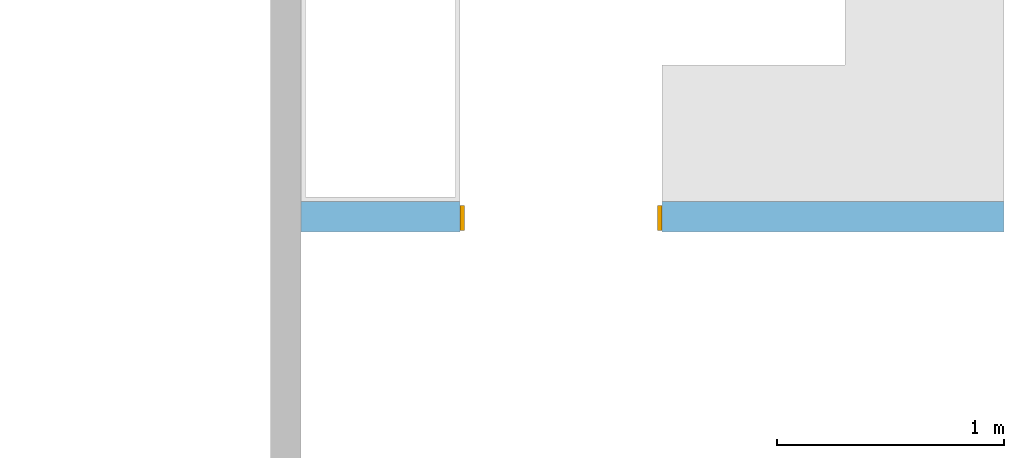
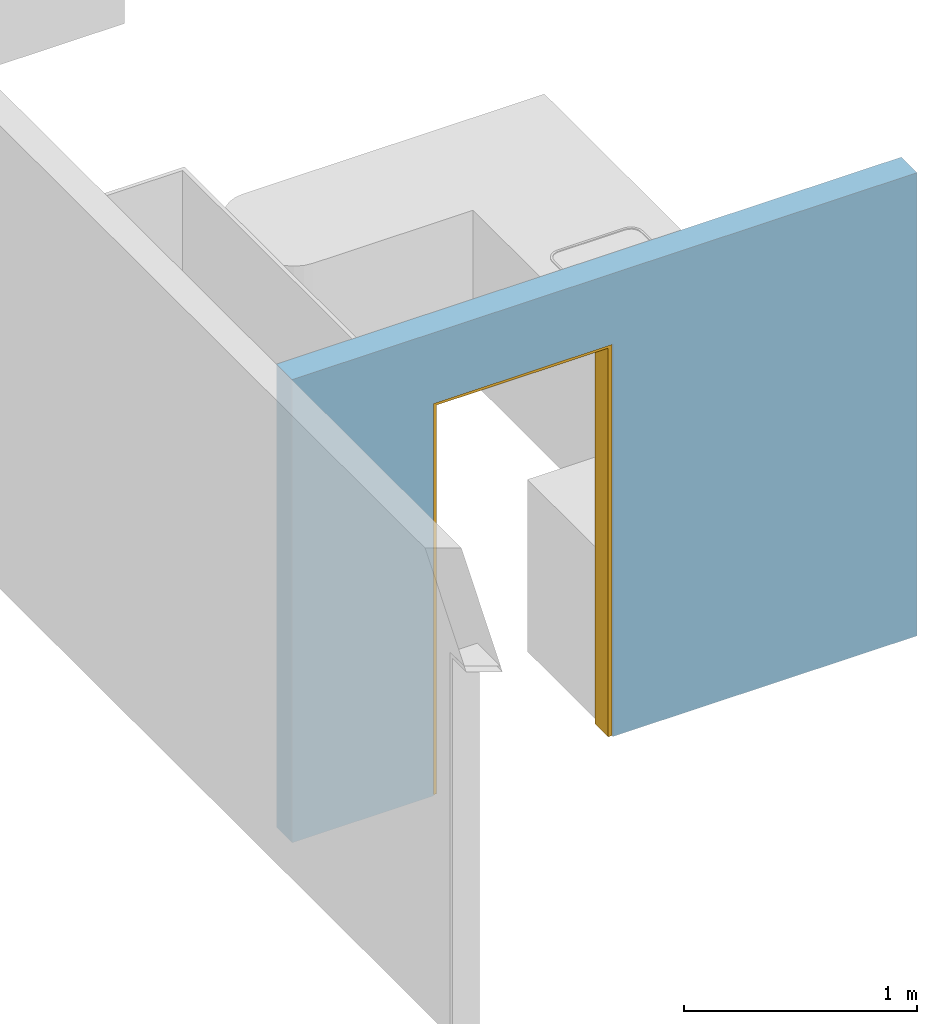
# One storey, part 3 of 6: 1 door, 1 opening, plus 1 element that does not belong to this part.
"""IFC4 building model written with IfcOpenShell, lengths in millimetres."""

import ifcopenshell
import ifcopenshell.guid

model = None  # the IFC model being written
_history = None  # IfcOwnerHistory: only IFC2X3 demands one
_inside = {}  # id of a spatial element -> (the spatial element, [elements in it])
_under = {}  # id of a project, library or spatial element -> (it, [spatial elements below it])
_declared = {}  # id of a project -> (the project, [libraries it declares])
_typed = {}  # id of a type object -> (the type object, [elements of that type])
_made_of = {}  # id of a material, layer set ... -> (it, [elements and type objects made of it])


def new_model(schema):
    """Start an empty IFC model of exactly this schema.

    Asked for "IFC4X3", IfcOpenShell would pick the latest addendum, in which some entities
    have other attributes; the version numbers below select the first issue.
    IFC2X3 requires an IfcOwnerHistory on every rooted entity: one is made here for all.
    """
    global model, _history
    if schema == "IFC4X3":
        model = ifcopenshell.file(schema_version=(4, 3, 0, 0))
    else:
        model = ifcopenshell.file(schema=schema)
    _inside.clear()
    _under.clear()
    _declared.clear()
    _typed.clear()
    _made_of.clear()
    _history = None
    if model.schema == "IFC2X3":
        org = make("IfcOrganization", Name="unknown")
        user = make(
            "IfcPersonAndOrganization",
            ThePerson=make("IfcPerson", FamilyName="unknown"),
            TheOrganization=org,
        )
        app = make(
            "IfcApplication",
            ApplicationDeveloper=org,
            Version="unknown",
            ApplicationFullName="unknown",
            ApplicationIdentifier="unknown",
        )
        _history = make(
            "IfcOwnerHistory",
            OwningUser=user,
            OwningApplication=app,
            ChangeAction="ADDED",
            CreationDate=0,
        )
    return model


def make(cls, **values):
    """One entity of the class cls with the attributes given. An attribute that is None is left unset."""
    return model.create_entity(
        cls, **{name: value for name, value in values.items() if value is not None}
    )


def entity(cls, *values):
    """Any entity or typed value of the class cls, its attributes in the order of the schema. None: left unset."""
    e = model.create_entity(cls)
    for i, value in enumerate(values):
        if value is not None:
            e[i] = value
    return e


def rooted(cls, **values):
    """An entity with a GlobalId (a new one), such as an element, a storey or a relation."""
    return make(cls, GlobalId=ifcopenshell.guid.new(), OwnerHistory=_history, **values)


def si_unit(unit_type, name, prefix=None):
    """IfcSIUnit, for example si_unit("LENGTHUNIT", "METRE", prefix="MILLI")."""
    return make("IfcSIUnit", UnitType=unit_type, Prefix=prefix, Name=name)


def converted_unit(unit_type, name, factor, base, dimensions=None, offset=None):
    """IfcConversionBasedUnit, such as the inch: factor (a typed value) times the base unit."""
    return make(
        "IfcConversionBasedUnit"
        if offset is None
        else "IfcConversionBasedUnitWithOffset",
        ConversionOffset=offset,
        Dimensions=None
        if dimensions is None
        else entity("IfcDimensionalExponents", *dimensions),
        UnitType=unit_type,
        Name=name,
        ConversionFactor=make(
            "IfcMeasureWithUnit", ValueComponent=factor, UnitComponent=base
        ),
    )


def assignment(units):
    """IfcUnitAssignment: the units of a project."""
    return None if units is None else make("IfcUnitAssignment", Units=units)


def point(xyz):
    """IfcCartesianPoint."""
    return None if xyz is None else make("IfcCartesianPoint", Coordinates=xyz)


def direction(xyz):
    """IfcDirection."""
    return None if xyz is None else make("IfcDirection", DirectionRatios=xyz)


def frame(location, z_axis=None, x_axis=None):
    """IfcAxis2Placement3D, a coordinate frame: its origin and axes. An axis left out is left unset."""
    return make(
        "IfcAxis2Placement3D",
        Location=point(location),
        Axis=direction(z_axis),
        RefDirection=direction(x_axis),
    )


def frame_2d(location, x_axis=None):
    """IfcAxis2Placement2D, a coordinate frame in the plane: its origin and x axis."""
    return make(
        "IfcAxis2Placement2D", Location=point(location), RefDirection=direction(x_axis)
    )


def origin_with_axes():
    """The frame at (0, 0, 0) with the z axis (0, 0, 1) and the x axis (1, 0, 0) written out."""
    return frame((0.0, 0.0, 0.0), z_axis=(0.0, 0.0, 1.0), x_axis=(1.0, 0.0, 0.0))


def origin_2d_with_axis():
    """The frame at (0, 0) in the plane with the x axis (1, 0) written out."""
    return frame_2d((0.0, 0.0), x_axis=(1.0, 0.0))


def place(relative_to, where):
    """IfcLocalPlacement: puts the frame where relative to a parent placement (None: the world)."""
    return make(
        "IfcLocalPlacement", PlacementRelTo=relative_to, RelativePlacement=where
    )


def context(
    kind, dimensions, precision=None, world=None, true_north=None, identifier=None
):
    """IfcGeometricRepresentationContext, for example the 3D "Model" context."""
    return make(
        "IfcGeometricRepresentationContext",
        ContextIdentifier=identifier,
        ContextType=kind,
        CoordinateSpaceDimension=dimensions,
        Precision=precision,
        WorldCoordinateSystem=world,
        TrueNorth=true_north,
    )


def subcontext(parent, identifier, kind, view, scale=None):
    """IfcGeometricRepresentationSubContext, for example "Body" below "Model"."""
    return make(
        "IfcGeometricRepresentationSubContext",
        ContextIdentifier=identifier,
        ContextType=kind,
        ParentContext=parent,
        TargetScale=scale,
        TargetView=view,
    )


def project(units=None, contexts=None):
    """IfcProject with its units and contexts."""
    return rooted(
        "IfcProject",
        Name="project",
        RepresentationContexts=contexts,
        UnitsInContext=assignment(units),
    )


def spatial(cls, under=None, at=None, **own):
    """A site, building, storey or space (cls), placed at a placement, below another one or the project."""
    s = rooted(cls, ObjectPlacement=at, **own)
    if under is not None:
        _under.setdefault(under.id(), (under, []))[1].append(s)
    return s


def point_list(points):
    """IfcCartesianPointList2D or 3D."""
    cls = (
        "IfcCartesianPointList2D" if len(points[0]) == 2 else "IfcCartesianPointList3D"
    )
    return make(cls, CoordList=points)


def line(*indices):
    """IfcLineIndex: a straight run through numbered points of an indexed curve."""
    return model.create_entity("IfcLineIndex", indices)


def indexed_curve(points, segments=None, self_intersect=None):
    """IfcIndexedPolyCurve: lines and arcs through numbered points (the first is 1)."""
    return make(
        "IfcIndexedPolyCurve",
        Points=point_list(points),
        Segments=segments,
        SelfIntersect=self_intersect,
    )


def outline(outer, holes=None, kind="AREA"):
    """IfcArbitraryClosedProfileDef: a profile drawn as a closed curve; with holes, ...WithVoids."""
    if holes is None:
        return make("IfcArbitraryClosedProfileDef", ProfileType=kind, OuterCurve=outer)
    return make(
        "IfcArbitraryProfileDefWithVoids",
        ProfileType=kind,
        OuterCurve=outer,
        InnerCurves=holes,
    )


def extrude(swept, where, along, depth):
    """IfcExtrudedAreaSolid: the profile swept, set in the frame where, extruded along a direction by depth."""
    return make(
        "IfcExtrudedAreaSolid",
        SweptArea=swept,
        Position=where,
        ExtrudedDirection=direction(along),
        Depth=depth,
    )


def polygons(points, faces, closed=None, point_numbers=None):
    """IfcPolygonalFaceSet: a face is its outer loop, then its inner loops; points numbered from 1."""
    made = []
    for loops in faces:
        if len(loops) == 1:
            made.append(make("IfcIndexedPolygonalFace", CoordIndex=loops[0]))
        else:
            made.append(
                make(
                    "IfcIndexedPolygonalFaceWithVoids",
                    CoordIndex=loops[0],
                    InnerCoordIndices=loops[1:],
                )
            )
    return make(
        "IfcPolygonalFaceSet",
        Coordinates=point_list(points),
        Closed=closed,
        Faces=made,
        PnIndex=point_numbers,
    )


def shape(context_of_items, identifier, shape_type, items):
    """IfcShapeRepresentation: the items that make up one representation, for example the "Body"."""
    return make(
        "IfcShapeRepresentation",
        ContextOfItems=context_of_items,
        RepresentationIdentifier=identifier,
        RepresentationType=shape_type,
        Items=items,
    )


def source(mapping_origin, context_of_items, identifier, shape_type, items):
    """IfcRepresentationMap: a shape defined once, which mapped items show again and again."""
    return make(
        "IfcRepresentationMap",
        MappingOrigin=mapping_origin,
        MappedRepresentation=shape(context_of_items, identifier, shape_type, items),
    )


def transform(
    local_origin,
    x_axis=None,
    y_axis=None,
    z_axis=None,
    scale=None,
    scale2=None,
    scale3=None,
    uniform=True,
):
    """IfcCartesianTransformationOperator3D, or its non-uniform kind. x_axis, y_axis, z_axis: its Axis1, 2, 3."""
    if uniform:
        return make(
            "IfcCartesianTransformationOperator3D",
            Axis1=direction(x_axis),
            Axis2=direction(y_axis),
            LocalOrigin=point(local_origin),
            Scale=scale,
            Axis3=direction(z_axis),
        )
    return make(
        "IfcCartesianTransformationOperator3DnonUniform",
        Axis1=direction(x_axis),
        Axis2=direction(y_axis),
        LocalOrigin=point(local_origin),
        Scale=scale,
        Axis3=direction(z_axis),
        Scale2=scale2,
        Scale3=scale3,
    )


def mapped(mapping_source, mapping_target):
    """IfcMappedItem: shows the shape of a source again, moved by a transform."""
    return make(
        "IfcMappedItem", MappingSource=mapping_source, MappingTarget=mapping_target
    )


def material(Name=None, Category=None):
    """IfcMaterial."""
    return make("IfcMaterial", Name=Name, Category=Category)


def layer(
    of_material, thickness, ventilated=None, Name=None, Category=None, Priority=None
):
    """IfcMaterialLayer: one layer of a wall or slab, of a material (None: an air gap)."""
    return make(
        "IfcMaterialLayer",
        Material=of_material,
        LayerThickness=thickness,
        IsVentilated=ventilated,
        Name=Name,
        Category=Category,
        Priority=Priority,
    )


def layer_set(layers, Name=None):
    """IfcMaterialLayerSet."""
    return make("IfcMaterialLayerSet", MaterialLayers=layers, LayerSetName=Name)


def layer_usage(for_layer_set, set_direction, sense, offset, extent=None):
    """IfcMaterialLayerSetUsage: how a layer set lies in its element."""
    return make(
        "IfcMaterialLayerSetUsage",
        ForLayerSet=for_layer_set,
        LayerSetDirection=set_direction,
        DirectionSense=sense,
        OffsetFromReferenceLine=offset,
        ReferenceExtent=extent,
    )


def made_of(thing, what):
    """Note that an element or type object is made of a material, layer set ...; save() writes the relation."""
    if what is not None:
        _made_of.setdefault(what.id(), (what, []))[1].append(thing)
    return thing


def type_object(cls, material=None, **own):
    """A type object (cls), such as IfcWallType, which elements share."""
    return made_of(rooted(cls, **own), material)


def type_shapes(of_type, sources):
    """Give a type object the sources (RepresentationMaps) that its elements show as mapped items."""
    of_type.RepresentationMaps = sources


def element(
    cls,
    number,
    at=None,
    inside=None,
    cuts=None,
    type_object=None,
    material=None,
    context=None,
    identifier="Body",
    shape_type=None,
    held_by="IfcProductDefinitionShape",
    body=None,
    shapes=None,
    **own,
):
    """One element of the class cls, such as IfcWall. Its Tag is "e" and its number.

    at: its placement. inside: the storey or other place that contains it. cuts: it is an
    opening in that element (IfcRelVoidsElement). A single representation is given by context,
    identifier, shape_type and body (its items); several are given by shapes. held_by: the class
    of the entity that holds the representations. save() writes the other relations.
    """
    e = rooted(cls, Tag="e%d" % number, ObjectPlacement=at, **own)
    if body is not None:
        shapes = [shape(context, identifier, shape_type, body)]
    if shapes is not None:
        e.Representation = make(held_by, Representations=shapes)
    if inside is not None:
        _inside.setdefault(inside.id(), (inside, []))[1].append(e)
    if cuts is not None:
        rooted(
            "IfcRelVoidsElement", RelatingBuildingElement=cuts, RelatedOpeningElement=e
        )
    if type_object is not None:
        _typed.setdefault(type_object.id(), (type_object, []))[1].append(e)
    return made_of(e, material)


def fill(opening, filler):
    """IfcRelFillsElement: the door or window that sits in an opening."""
    return rooted(
        "IfcRelFillsElement",
        RelatingOpeningElement=opening,
        RelatedBuildingElement=filler,
    )


def aggregate(whole, parts):
    """IfcRelAggregates: a whole, such as a stair, and the parts it consists of."""
    return rooted("IfcRelAggregates", RelatingObject=whole, RelatedObjects=parts)


def save(model, path):
    """Write the relations noted so far, then the file.

    IfcRelAggregates (storeys below a building ...), IfcRelContainedInSpatialStructure (elements
    in a storey), IfcRelDefinesByType, IfcRelAssociatesMaterial and IfcRelDeclares: one each for
    every whole, place, type object, material and project.
    """
    for whole, parts in _under.values():
        aggregate(whole, parts)
    for where, things in _inside.values():
        rooted(
            "IfcRelContainedInSpatialStructure",
            RelatedElements=things,
            RelatingStructure=where,
        )
    for kind, things in _typed.values():
        rooted("IfcRelDefinesByType", RelatedObjects=things, RelatingType=kind)
    for what, things in _made_of.values():
        rooted("IfcRelAssociatesMaterial", RelatedObjects=things, RelatingMaterial=what)
    for by, libraries in _declared.values():
        rooted("IfcRelDeclares", RelatingContext=by, RelatedDefinitions=libraries)
    model.write(path)


model = new_model("IFC4")

# Units and contexts
model_context = context("Model", 3, precision=1e-05, world=origin_with_axes())
plan_context = context("Plan", 2, precision=1e-05, world=origin_2d_with_axis())
body_context = subcontext(model_context, "Body", "Model", "MODEL_VIEW")
ifc_project = project(units=[si_unit("VOLUMEUNIT", "CUBIC_METRE"), si_unit("LENGTHUNIT", "METRE", prefix="MILLI"), converted_unit("PLANEANGLEUNIT", "degree", entity("IfcReal", 0.0174532925199433), si_unit("PLANEANGLEUNIT", "RADIAN"), dimensions=[0, 0, 0, 0, 0, 0, 0]), si_unit("AREAUNIT", "SQUARE_METRE")], contexts=[model_context, plan_context])

# Site, building, storey
site_placement = place(None, origin_with_axes())
site = spatial("IfcSite", under=ifc_project, at=site_placement)
building_placement = place(site_placement, origin_with_axes())
building = spatial("IfcBuilding", under=site, at=building_placement, Name="Building")
storey_placement = place(building_placement, origin_with_axes())
storey = spatial("IfcBuildingStorey", under=building, at=storey_placement, Name="DEMO")

# Wall, opening, door
ifc_material = material()
ifc_layer = layer(ifc_material, 135.0)
ifc_layer_set = layer_set([ifc_layer])
ifc_layer_usage = layer_usage(ifc_layer_set, "AXIS2", "POSITIVE", 0.0)
wall_type = type_object("IfcWallType", Name="WAL135", PredefinedType="NOTDEFINED", material=ifc_layer_set)
wall_placement = place(storey_placement, frame((10114.1214370728, -653.332471847534, 0.0), z_axis=(0.0, 0.0, 1.0), x_axis=(0.999999999999993, 1.19209282445353e-07, 0.0)))
wall = element("IfcWall", 1, at=wall_placement, inside=storey, type_object=wall_type, material=ifc_layer_usage, Name="Wall", context=body_context, shape_type="SweptSolid", body=[
    extrude(outline(indexed_curve([(0.0, 0.0), (0.0, 135.0), (3094.9992730505, 135.0), (3094.9992730505, 0.0), (0.0, 0.0)], self_intersect=False)), origin_with_axes(), (0.0, 0.0, 1.0), 2425.00019073486),
])
shared_shape_1 = source(origin_with_axes(), body_context, "Body", "SweptSolid", [
    extrude(outline(indexed_curve([(0.0, 0.0), (890.001281738281, 0.0), (890.001281738281, 2055.0), (0.0, 2055.0)], segments=[line(1, 2, 3, 4, 1)])), frame((2.38418564890708e-07, -600.0, 0.0), z_axis=(0.0, -1.0, 0.0), x_axis=(1.0, 0.0, 0.0)), (0.0, 0.0, -1.0), 1200.0),
])
opening_placement = place(wall_placement, frame((699.99984382384, 63.0001493304366, 0.0), z_axis=(0.0, 0.0, 1.0), x_axis=(0.999999999999993, 1.19209282445351e-07, 0.0)))
opening = element("IfcOpeningElement", 2, at=opening_placement, cuts=wall, PredefinedType="OPENING", context=body_context, shape_type="MappedRepresentation", body=[
    mapped(shared_shape_1, transform((0.0, 0.0, 0.0), x_axis=(1.0, 0.0, 0.0), y_axis=(0.0, 1.0, 0.0), z_axis=(0.0, 0.0, 1.0), scale=1.0)),
])
door_type = type_object("IfcDoorType", OperationType="NOTDEFINED", PredefinedType="DOOR")
shared_shape_2 = source(origin_with_axes(), body_context, "Body", "Tessellation", [
    polygons([(0.000238418564549647, -54.9999504089355, 0.0), (20.0006942749023, -54.9999504089355, 0.0), (0.000238418564549647, -55.0000190734863, 2035.0), (20.0006942749023, -55.0000190734863, 2035.0), (0.000238418564549647, 54.9999847412109, 0.0), (20.0006942749023, 54.9999885559082, 0.0), (0.000238418564549647, 54.9999504089355, 2035.0), (20.0006942749023, 54.9999542236328, 2035.0), (890.001586914062, -54.9999656677246, 2035.0), (890.001586914062, -54.9999656677246, 2055.0), (0.000238418564549647, -55.0000190734863, 2034.99975585938), (0.000238418564549647, -55.0000190734863, 2054.99975585938), (890.001098632812, 55.0000076293945, 2035.0), (890.001098632812, 55.0000076293945, 2055.0), (0.000238418564549647, 54.9999504089355, 2034.99975585938), (0.000238418564549647, 54.9999504089355, 2054.99975585938), (870.001159667969, -54.9999656677246, 0.0), (890.001098632812, -54.9999656677246, 0.0), (870.001159667969, -54.9999961853027, 2035.0), (890.001098632812, -54.9999961853027, 2035.0), (870.001159667969, 55.0000038146973, 0.0), (890.001098632812, 55.0000076293945, 0.0), (870.000671386719, 54.9999389648438, 2035.0), (890.000671386719, 54.9999389648438, 2035.0)], [[[1, 2, 4, 3]], [[3, 4, 8, 7]], [[7, 8, 6, 5]], [[5, 6, 2, 1]], [[3, 7, 5, 1]], [[8, 4, 2, 6]], [[9, 10, 12, 11]], [[11, 12, 16, 15]], [[15, 16, 14, 13]], [[13, 14, 10, 9]], [[11, 15, 13, 9]], [[16, 12, 10, 14]], [[17, 18, 20, 19]], [[19, 20, 24, 23]], [[23, 24, 22, 21]], [[21, 22, 18, 17]], [[19, 23, 21, 17]], [[24, 20, 18, 22]]], closed=True),
])
type_shapes(door_type, [shared_shape_2])
door_placement = place(opening_placement, frame((-2.70487188203106e-05, -0.000745853691253018, 0.0), z_axis=(0.0, 0.0, 1.0), x_axis=(1.0, -1.27054942088145e-21, 0.0)))
door = element("IfcDoor", 3, at=door_placement, inside=storey, type_object=door_type, Name="Door", context=body_context, shape_type="MappedRepresentation", body=[
    mapped(shared_shape_2, transform((0.0, 0.0, 0.0), x_axis=(1.0, 0.0, 0.0), y_axis=(0.0, 1.0, 0.0), z_axis=(0.0, 0.0, 1.0), scale=1.0)),
])
fill(opening, door)

save(model, "model.ifc")
